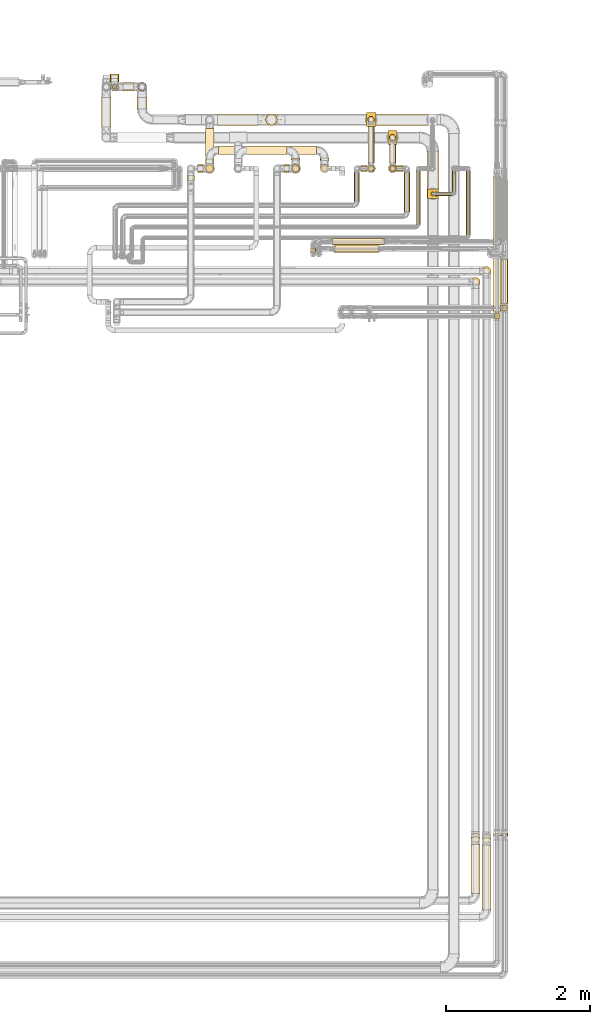
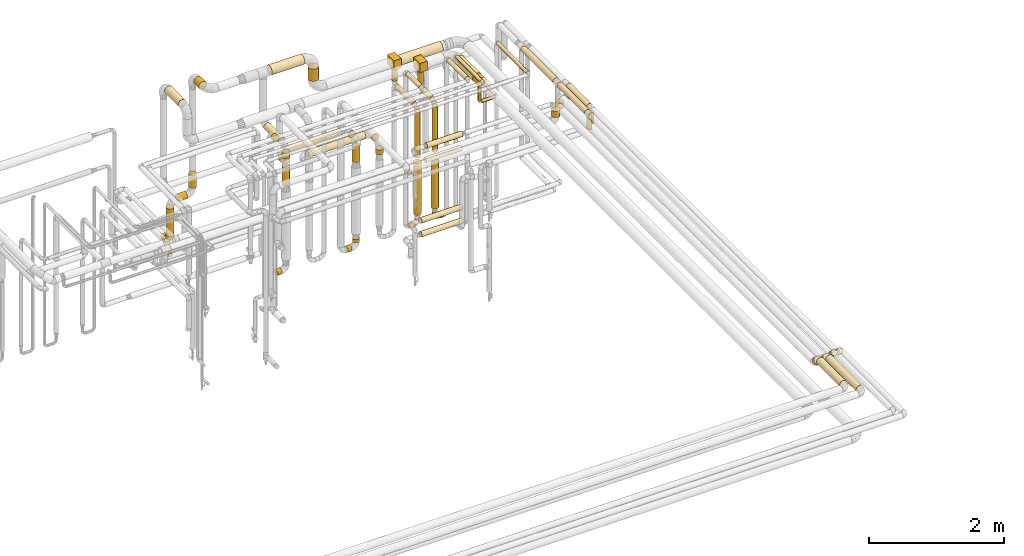
# One storey, part 18 of 827: 66 coverings.
"""IFC2X3 building model written with IfcOpenShell, lengths in millimetres."""

import ifcopenshell
import ifcopenshell.guid

model = None  # the IFC model being written
_history = None  # IfcOwnerHistory: only IFC2X3 demands one
_inside = {}  # id of a spatial element -> (the spatial element, [elements in it])
_under = {}  # id of a project, library or spatial element -> (it, [spatial elements below it])
_declared = {}  # id of a project -> (the project, [libraries it declares])
_typed = {}  # id of a type object -> (the type object, [elements of that type])
_made_of = {}  # id of a material, layer set ... -> (it, [elements and type objects made of it])


def new_model(schema):
    """Start an empty IFC model of exactly this schema.

    Asked for "IFC4X3", IfcOpenShell would pick the latest addendum, in which some entities
    have other attributes; the version numbers below select the first issue.
    IFC2X3 requires an IfcOwnerHistory on every rooted entity: one is made here for all.
    """
    global model, _history
    if schema == "IFC4X3":
        model = ifcopenshell.file(schema_version=(4, 3, 0, 0))
    else:
        model = ifcopenshell.file(schema=schema)
    _inside.clear()
    _under.clear()
    _declared.clear()
    _typed.clear()
    _made_of.clear()
    _history = None
    if model.schema == "IFC2X3":
        org = make("IfcOrganization", Name="unknown")
        user = make(
            "IfcPersonAndOrganization",
            ThePerson=make("IfcPerson", FamilyName="unknown"),
            TheOrganization=org,
        )
        app = make(
            "IfcApplication",
            ApplicationDeveloper=org,
            Version="unknown",
            ApplicationFullName="unknown",
            ApplicationIdentifier="unknown",
        )
        _history = make(
            "IfcOwnerHistory",
            OwningUser=user,
            OwningApplication=app,
            ChangeAction="ADDED",
            CreationDate=0,
        )
    return model


def make(cls, **values):
    """One entity of the class cls with the attributes given. An attribute that is None is left unset."""
    return model.create_entity(
        cls, **{name: value for name, value in values.items() if value is not None}
    )


def entity(cls, *values):
    """Any entity or typed value of the class cls, its attributes in the order of the schema. None: left unset."""
    e = model.create_entity(cls)
    for i, value in enumerate(values):
        if value is not None:
            e[i] = value
    return e


def rooted(cls, **values):
    """An entity with a GlobalId (a new one), such as an element, a storey or a relation."""
    return make(cls, GlobalId=ifcopenshell.guid.new(), OwnerHistory=_history, **values)


def si_unit(unit_type, name, prefix=None):
    """IfcSIUnit, for example si_unit("LENGTHUNIT", "METRE", prefix="MILLI")."""
    return make("IfcSIUnit", UnitType=unit_type, Prefix=prefix, Name=name)


def converted_unit(unit_type, name, factor, base, dimensions=None, offset=None):
    """IfcConversionBasedUnit, such as the inch: factor (a typed value) times the base unit."""
    return make(
        "IfcConversionBasedUnit"
        if offset is None
        else "IfcConversionBasedUnitWithOffset",
        ConversionOffset=offset,
        Dimensions=None
        if dimensions is None
        else entity("IfcDimensionalExponents", *dimensions),
        UnitType=unit_type,
        Name=name,
        ConversionFactor=make(
            "IfcMeasureWithUnit", ValueComponent=factor, UnitComponent=base
        ),
    )


def derived_unit(unit_type, elements):
    """IfcDerivedUnit: a product of units, each with its exponent."""
    return make(
        "IfcDerivedUnit",
        Elements=[
            make("IfcDerivedUnitElement", Unit=unit, Exponent=power)
            for unit, power in elements
        ],
        UnitType=unit_type,
    )


def assignment(units):
    """IfcUnitAssignment: the units of a project."""
    return None if units is None else make("IfcUnitAssignment", Units=units)


def point(xyz):
    """IfcCartesianPoint."""
    return None if xyz is None else make("IfcCartesianPoint", Coordinates=xyz)


def direction(xyz):
    """IfcDirection."""
    return None if xyz is None else make("IfcDirection", DirectionRatios=xyz)


def frame(location, z_axis=None, x_axis=None):
    """IfcAxis2Placement3D, a coordinate frame: its origin and axes. An axis left out is left unset."""
    return make(
        "IfcAxis2Placement3D",
        Location=point(location),
        Axis=direction(z_axis),
        RefDirection=direction(x_axis),
    )


def frame_2d(location, x_axis=None):
    """IfcAxis2Placement2D, a coordinate frame in the plane: its origin and x axis."""
    return make(
        "IfcAxis2Placement2D", Location=point(location), RefDirection=direction(x_axis)
    )


def origin():
    """The frame at (0, 0, 0) with its axes left unset."""
    return frame((0.0, 0.0, 0.0))


def origin_2d_with_axis():
    """The frame at (0, 0) in the plane with the x axis (1, 0) written out."""
    return frame_2d((0.0, 0.0), x_axis=(1.0, 0.0))


def place(relative_to, where):
    """IfcLocalPlacement: puts the frame where relative to a parent placement (None: the world)."""
    return make(
        "IfcLocalPlacement", PlacementRelTo=relative_to, RelativePlacement=where
    )


def context(
    kind, dimensions, precision=None, world=None, true_north=None, identifier=None
):
    """IfcGeometricRepresentationContext, for example the 3D "Model" context."""
    return make(
        "IfcGeometricRepresentationContext",
        ContextIdentifier=identifier,
        ContextType=kind,
        CoordinateSpaceDimension=dimensions,
        Precision=precision,
        WorldCoordinateSystem=world,
        TrueNorth=true_north,
    )


def subcontext(parent, identifier, kind, view, scale=None):
    """IfcGeometricRepresentationSubContext, for example "Body" below "Model"."""
    return make(
        "IfcGeometricRepresentationSubContext",
        ContextIdentifier=identifier,
        ContextType=kind,
        ParentContext=parent,
        TargetScale=scale,
        TargetView=view,
    )


def project(units=None, contexts=None):
    """IfcProject with its units and contexts."""
    return rooted(
        "IfcProject",
        Name="project",
        RepresentationContexts=contexts,
        UnitsInContext=assignment(units),
    )


def spatial(cls, under=None, at=None, **own):
    """A site, building, storey or space (cls), placed at a placement, below another one or the project."""
    s = rooted(cls, ObjectPlacement=at, **own)
    if under is not None:
        _under.setdefault(under.id(), (under, []))[1].append(s)
    return s


def polyline(points):
    """IfcPolyline through the points."""
    return make("IfcPolyline", Points=[point(p) for p in points])


def circle_curve(where, radius):
    """IfcCircle in the frame where."""
    return make("IfcCircle", Position=where, Radius=radius)


def parameter(value):
    """IfcParameterValue: where a trimmed curve begins or ends, as a parameter of its basis curve."""
    return model.create_entity("IfcParameterValue", value)


def trimmed(basis, trim1, trim2, sense, master):
    """IfcTrimmedCurve: the piece of a basis curve between two trims."""
    return make(
        "IfcTrimmedCurve",
        BasisCurve=basis,
        Trim1=trim1,
        Trim2=trim2,
        SenseAgreement=sense,
        MasterRepresentation=master,
    )


def segment(curve, same_sense, transition):
    """IfcCompositeCurveSegment."""
    return make(
        "IfcCompositeCurveSegment",
        Transition=transition,
        SameSense=same_sense,
        ParentCurve=curve,
    )


def composite_curve(segments, self_intersect=None):
    """IfcCompositeCurve: segments joined end to end."""
    return make("IfcCompositeCurve", Segments=segments, SelfIntersect=self_intersect)


def profile(cls, at=None, kind="AREA", **sizes):
    """A parametric profile (cls). Its sizes go by their IFC names, for example OverallWidth=200.0."""
    return make(cls, ProfileType=kind, Position=at, **sizes)


def rectangle(**sizes):
    """IfcRectangleProfileDef."""
    return profile("IfcRectangleProfileDef", **sizes)


def circle(**sizes):
    """IfcCircleProfileDef."""
    return profile("IfcCircleProfileDef", **sizes)


def outline(outer, holes=None, kind="AREA"):
    """IfcArbitraryClosedProfileDef: a profile drawn as a closed curve; with holes, ...WithVoids."""
    if holes is None:
        return make("IfcArbitraryClosedProfileDef", ProfileType=kind, OuterCurve=outer)
    return make(
        "IfcArbitraryProfileDefWithVoids",
        ProfileType=kind,
        OuterCurve=outer,
        InnerCurves=holes,
    )


def extrude(swept, where, along, depth):
    """IfcExtrudedAreaSolid: the profile swept, set in the frame where, extruded along a direction by depth."""
    return make(
        "IfcExtrudedAreaSolid",
        SweptArea=swept,
        Position=where,
        ExtrudedDirection=direction(along),
        Depth=depth,
    )


def shape(context_of_items, identifier, shape_type, items):
    """IfcShapeRepresentation: the items that make up one representation, for example the "Body"."""
    return make(
        "IfcShapeRepresentation",
        ContextOfItems=context_of_items,
        RepresentationIdentifier=identifier,
        RepresentationType=shape_type,
        Items=items,
    )


def made_of(thing, what):
    """Note that an element or type object is made of a material, layer set ...; save() writes the relation."""
    if what is not None:
        _made_of.setdefault(what.id(), (what, []))[1].append(thing)
    return thing


def element(
    cls,
    number,
    at=None,
    inside=None,
    cuts=None,
    type_object=None,
    material=None,
    context=None,
    identifier="Body",
    shape_type=None,
    held_by="IfcProductDefinitionShape",
    body=None,
    shapes=None,
    **own,
):
    """One element of the class cls, such as IfcWall. Its Tag is "e" and its number.

    at: its placement. inside: the storey or other place that contains it. cuts: it is an
    opening in that element (IfcRelVoidsElement). A single representation is given by context,
    identifier, shape_type and body (its items); several are given by shapes. held_by: the class
    of the entity that holds the representations. save() writes the other relations.
    """
    e = rooted(cls, Tag="e%d" % number, ObjectPlacement=at, **own)
    if body is not None:
        shapes = [shape(context, identifier, shape_type, body)]
    if shapes is not None:
        e.Representation = make(held_by, Representations=shapes)
    if inside is not None:
        _inside.setdefault(inside.id(), (inside, []))[1].append(e)
    if cuts is not None:
        rooted(
            "IfcRelVoidsElement", RelatingBuildingElement=cuts, RelatedOpeningElement=e
        )
    if type_object is not None:
        _typed.setdefault(type_object.id(), (type_object, []))[1].append(e)
    return made_of(e, material)


def aggregate(whole, parts):
    """IfcRelAggregates: a whole, such as a stair, and the parts it consists of."""
    return rooted("IfcRelAggregates", RelatingObject=whole, RelatedObjects=parts)


def save(model, path):
    """Write the relations noted so far, then the file.

    IfcRelAggregates (storeys below a building ...), IfcRelContainedInSpatialStructure (elements
    in a storey), IfcRelDefinesByType, IfcRelAssociatesMaterial and IfcRelDeclares: one each for
    every whole, place, type object, material and project.
    """
    for whole, parts in _under.values():
        aggregate(whole, parts)
    for where, things in _inside.values():
        rooted(
            "IfcRelContainedInSpatialStructure",
            RelatedElements=things,
            RelatingStructure=where,
        )
    for kind, things in _typed.values():
        rooted("IfcRelDefinesByType", RelatedObjects=things, RelatingType=kind)
    for what, things in _made_of.values():
        rooted("IfcRelAssociatesMaterial", RelatedObjects=things, RelatingMaterial=what)
    for by, libraries in _declared.values():
        rooted("IfcRelDeclares", RelatingContext=by, RelatedDefinitions=libraries)
    model.write(path)


model = new_model("IFC2X3")

# Units and contexts
model_context = context("Model", 3, precision=0.01, world=origin(), true_north=direction((6.12303176911189e-17, 1.0)))
body_context = subcontext(model_context, "Body", "Model", "MODEL_VIEW")
ifc_project = project(units=[si_unit("LENGTHUNIT", "METRE", prefix="MILLI"), si_unit("AREAUNIT", "SQUARE_METRE"), si_unit("VOLUMEUNIT", "CUBIC_METRE"), converted_unit("PLANEANGLEUNIT", "DEGREE", entity("IfcRatioMeasure", 0.0174532925199433), si_unit("PLANEANGLEUNIT", "RADIAN"), dimensions=[0, 0, 0, 0, 0, 0, 0]), si_unit("MASSUNIT", "GRAM", prefix="KILO"), derived_unit("MASSDENSITYUNIT", [(si_unit("MASSUNIT", "GRAM", prefix="KILO"), 1), (si_unit("LENGTHUNIT", "METRE"), -3)]), derived_unit("MOMENTOFINERTIAUNIT", [(si_unit("LENGTHUNIT", "METRE"), 4)]), si_unit("TIMEUNIT", "SECOND"), si_unit("FREQUENCYUNIT", "HERTZ"), si_unit("THERMODYNAMICTEMPERATUREUNIT", "DEGREE_CELSIUS"), derived_unit("THERMALTRANSMITTANCEUNIT", [(si_unit("MASSUNIT", "GRAM", prefix="KILO"), 1), (si_unit("THERMODYNAMICTEMPERATUREUNIT", "KELVIN"), -1), (si_unit("TIMEUNIT", "SECOND"), -3)]), derived_unit("VOLUMETRICFLOWRATEUNIT", [(si_unit("LENGTHUNIT", "METRE"), 3), (si_unit("TIMEUNIT", "SECOND"), -1)]), derived_unit("MASSFLOWRATEUNIT", [(si_unit("MASSUNIT", "GRAM", prefix="KILO"), 1), (si_unit("TIMEUNIT", "SECOND"), -1)]), derived_unit("ROTATIONALFREQUENCYUNIT", [(si_unit("TIMEUNIT", "SECOND"), -1)]), si_unit("ELECTRICCURRENTUNIT", "AMPERE"), si_unit("ELECTRICVOLTAGEUNIT", "VOLT"), si_unit("POWERUNIT", "WATT"), si_unit("FORCEUNIT", "NEWTON", prefix="KILO"), si_unit("ILLUMINANCEUNIT", "LUX"), si_unit("LUMINOUSFLUXUNIT", "LUMEN"), si_unit("LUMINOUSINTENSITYUNIT", "CANDELA"), derived_unit("USERDEFINED", [(si_unit("MASSUNIT", "GRAM", prefix="KILO"), -1), (si_unit("LENGTHUNIT", "METRE"), -2), (si_unit("TIMEUNIT", "SECOND"), 3), (si_unit("LUMINOUSFLUXUNIT", "LUMEN"), 1)]), derived_unit("LINEARVELOCITYUNIT", [(si_unit("LENGTHUNIT", "METRE"), 1), (si_unit("TIMEUNIT", "SECOND"), -1)]), si_unit("PRESSUREUNIT", "PASCAL"), derived_unit("USERDEFINED", [(si_unit("LENGTHUNIT", "METRE"), -2), (si_unit("MASSUNIT", "GRAM", prefix="KILO"), 1), (si_unit("TIMEUNIT", "SECOND"), -2)]), derived_unit("LINEARFORCEUNIT", [(si_unit("MASSUNIT", "GRAM", prefix="KILO"), 1), (si_unit("LENGTHUNIT", "METRE"), 1), (si_unit("TIMEUNIT", "SECOND"), -2), (si_unit("LENGTHUNIT", "METRE"), -1)]), derived_unit("PLANARFORCEUNIT", [(si_unit("MASSUNIT", "GRAM", prefix="KILO"), 1), (si_unit("LENGTHUNIT", "METRE"), 1), (si_unit("TIMEUNIT", "SECOND"), -2), (si_unit("LENGTHUNIT", "METRE"), -2)])], contexts=[model_context])

# Site, building, storey
site_placement = place(None, origin())
site = spatial("IfcSite", under=ifc_project, at=site_placement, CompositionType="ELEMENT")
building_placement = place(site_placement, origin())
building = spatial("IfcBuilding", under=site, at=building_placement, CompositionType="ELEMENT")
storey_placement = place(building_placement, frame((0.0, 0.0, 28200.0)))
storey = spatial("IfcBuildingStorey", under=building, at=storey_placement, Name="08", CompositionType="ELEMENT", Elevation=28200.0)

# Coverings
covering_1_placement = place(storey_placement, frame((60838.76, 16008.03, 2795.04)))
element("IfcCovering", 1, at=covering_1_placement, inside=storey, Name=":ADSK_", ObjectType=":ADSK_", PredefinedType="INSULATION", context=body_context, shape_type="SweptSolid", body=[
    extrude(circle(Radius=62.75, at=origin_2d_with_axis()), frame((64.35, 64.35, 0.0)), (0.0, 0.0, 1.0), 109.962845985803),
])
covering_2_placement = place(storey_placement, frame((59550.07, 17576.0, 2448.15)))
element("IfcCovering", 2, at=covering_2_placement, inside=storey, Name=":ADSK_", ObjectType=":ADSK_", PredefinedType="INSULATION", context=body_context, shape_type="SweptSolid", body=[
    extrude(circle(Radius=45.0, at=origin_2d_with_axis()), frame((46.6, 0.0, 46.6), z_axis=(0.0, 1.0, 0.0), x_axis=(1.0, 0.0, 0.0)), (0.0, 0.0, 1.0), 278.096097794324),
])
covering_3_placement = place(storey_placement, frame((59550.07, 17453.4, 1602.24)))
element("IfcCovering", 3, at=covering_3_placement, inside=storey, Name=":ADSK_", ObjectType=":ADSK_", PredefinedType="INSULATION", context=body_context, shape_type="SweptSolid", body=[
    extrude(circle(Radius=45.0, at=origin_2d_with_axis()), frame((46.6, 46.6, 0.0), z_axis=(0.0, 0.0, 1.0), x_axis=(0.0, 1.0, 0.0)), (0.0, 0.0, 1.0), 816.499999999996),
])
covering_4_placement = place(storey_placement, frame((60128.55, 17117.79, 2531.09)))
element("IfcCovering", 4, at=covering_4_placement, inside=storey, Name=":ADSK_", ObjectType=":ADSK_", PredefinedType="INSULATION", context=body_context, shape_type="SweptSolid", body=[
    extrude(circle(Radius=28.4, at=origin_2d_with_axis()), frame((30.0, 30.0, 0.0), z_axis=(-1.46203474159763e-05, 0.0, 1.0), x_axis=(0.0, 1.0, 0.0)), (0.0, 0.0, 1.0), 298.905011104185),
])
covering_5_placement = place(storey_placement, frame((60075.45, 17212.79, 2816.87)))
element("IfcCovering", 5, at=covering_5_placement, inside=storey, Name=":ADSK_", ObjectType=":ADSK_", PredefinedType="INSULATION", context=body_context, shape_type="SweptSolid", body=[
    extrude(circle(Radius=81.5, at=origin_2d_with_axis()), frame((83.1, 0.0, 83.1), z_axis=(0.0, 1.0, 0.0), x_axis=(1.0, 0.0, 0.0)), (0.0, 0.0, 1.0), 527.308325226667),
])
covering_6_placement = place(storey_placement, frame((60187.65, 17117.79, 2472.0)))
element("IfcCovering", 6, at=covering_6_placement, inside=storey, Name=":ADSK_", ObjectType=":ADSK_", PredefinedType="INSULATION", context=body_context, shape_type="SweptSolid", body=[
    extrude(circle(Radius=28.4, at=origin_2d_with_axis()), frame((0.0, 30.0, 30.0), z_axis=(1.0, 0.0, 0.0), x_axis=(0.0, 1.0, 0.0)), (0.0, 0.0, 1.0), 237.633062103833),
])
covering_7_placement = place(storey_placement, frame((60424.39, 17176.89, 2472.0)))
element("IfcCovering", 7, at=covering_7_placement, inside=storey, Name=":ADSK_", ObjectType=":ADSK_", PredefinedType="INSULATION", context=body_context, shape_type="SweptSolid", body=[
    extrude(circle(Radius=28.4, at=origin_2d_with_axis()), frame((30.0, 0.0, 30.0), z_axis=(0.0, 1.0, 0.0), x_axis=(-1.0, 0.0, 0.0)), (0.0, 0.0, 1.0), 294.012227432359),
])
covering_8_placement = place(storey_placement, frame((58588.54, 17614.0, 2039.15)))
element("IfcCovering", 8, at=covering_8_placement, inside=storey, Name=":ADSK_", ObjectType=":ADSK_", PredefinedType="INSULATION", context=body_context, shape_type="SweptSolid", body=[
    extrude(circle(Radius=59.25, at=origin_2d_with_axis()), frame((60.85, 0.0, 60.85), z_axis=(0.0, 1.0, 0.0), x_axis=(1.0, 0.0, 0.0)), (0.0, 0.0, 1.0), 27.0961141089868),
])
covering_9_placement = place(storey_placement, frame((58588.54, 17439.15, 1898.17)))
element("IfcCovering", 9, at=covering_9_placement, inside=storey, Name=":ADSK_", ObjectType=":ADSK_", PredefinedType="INSULATION", context=body_context, shape_type="SweptSolid", body=[
    extrude(circle(Radius=59.25, at=origin_2d_with_axis()), frame((60.85, 60.85, 0.0)), (0.0, 0.0, 1.0), 87.8307333425285),
])
covering_10_placement = place(storey_placement, frame((61002.04, 16436.84, 2949.15)))
element("IfcCovering", 10, at=covering_10_placement, inside=storey, Name=":ADSK_", ObjectType=":ADSK_", PredefinedType="INSULATION", context=body_context, shape_type="SweptSolid", body=[
    extrude(circle(Radius=49.0, at=origin_2d_with_axis()), frame((50.6, 0.0, 50.6), z_axis=(0.0, 1.0, 0.0), x_axis=(1.0, 0.0, 0.0)), (0.0, 0.0, 1.0), 958.995662655606),
])
covering_11_placement = place(storey_placement, frame((61002.04, 15501.21, 2949.15)))
element("IfcCovering", 11, at=covering_11_placement, inside=storey, Name=":ADSK_", ObjectType=":ADSK_", PredefinedType="INSULATION", context=body_context, shape_type="SweptSolid", body=[
    extrude(circle(Radius=49.0, at=origin_2d_with_axis()), frame((50.6, 0.0, 50.6), z_axis=(0.0, 1.0, 0.0), x_axis=(-1.0, 0.0, 0.0)), (0.0, 0.0, 1.0), 821.627947057632),
])
covering_12_placement = place(storey_placement, frame((61009.29, 15400.86, 2738.0)))
element("IfcCovering", 12, at=covering_12_placement, inside=storey, Name=":ADSK_", ObjectType=":ADSK_", PredefinedType="INSULATION", context=body_context, shape_type="SweptSolid", body=[
    extrude(circle(Radius=41.75, at=origin_2d_with_axis()), frame((43.35, 43.35, 0.0), z_axis=(0.0, 0.0, 1.0), x_axis=(0.0, -1.0, 0.0)), (0.0, 0.0, 1.0), 204.743188805694),
])
covering_13_placement = place(storey_placement, frame((61102.04, 15617.52, 2949.15)))
element("IfcCovering", 13, at=covering_13_placement, inside=storey, Name=":ADSK_", ObjectType=":ADSK_", PredefinedType="INSULATION", context=body_context, shape_type="SweptSolid", body=[
    extrude(circle(Radius=49.0, at=origin_2d_with_axis()), frame((50.6, 0.0, 50.6), z_axis=(0.0, 1.0, 0.0), x_axis=(-1.0, 0.0, 0.0)), (0.0, 0.0, 1.0), 614.353457594442),
])
covering_14_placement = place(storey_placement, frame((61109.29, 15517.18, 2738.0)))
element("IfcCovering", 14, at=covering_14_placement, inside=storey, Name=":ADSK_", ObjectType=":ADSK_", PredefinedType="INSULATION", context=body_context, shape_type="SweptSolid", body=[
    extrude(circle(Radius=41.75, at=origin_2d_with_axis()), frame((43.35, 43.35, 0.0), z_axis=(0.0, 0.0, 1.0), x_axis=(0.0, -1.0, 0.0)), (0.0, 0.0, 1.0), 204.743188805685),
])
covering_15_placement = place(storey_placement, frame((55540.45, 18080.1, 3429.4)))
element("IfcCovering", 15, at=covering_15_placement, inside=storey, Name=":ADSK_", ObjectType=":ADSK_", PredefinedType="INSULATION", context=body_context, shape_type="SweptSolid", body=[
    extrude(circle(Radius=69.0, at=origin_2d_with_axis()), frame((70.6, 0.0, 70.6), z_axis=(0.0, 1.0, 0.0), x_axis=(-1.0, 0.0, 0.0)), (0.0, 0.0, 1.0), 405.890503073728),
])
covering_16_placement = place(storey_placement, frame((59550.07, 17883.5, 2570.74)))
element("IfcCovering", 16, at=covering_16_placement, inside=storey, Name=":ADSK_", ObjectType=":ADSK_", PredefinedType="INSULATION", context=body_context, shape_type="SweptSolid", body=[
    extrude(circle(Radius=45.0, at=origin_2d_with_axis()), frame((46.6, 46.6, 0.0)), (0.0, 0.0, 1.0), 259.256811194313),
])
covering_17_placement = place(storey_placement, frame((59531.67, 17833.85, 2830.0)))
element("IfcCovering", 17, at=covering_17_placement, inside=storey, Name=":ADSK_", ObjectType=":ADSK_", PredefinedType="INSULATION", context=body_context, shape_type="SweptSolid", body=[
    extrude(rectangle(XDim=129.999999999996, YDim=192.500000000002, at=origin_2d_with_axis()), frame((65.0, 96.25, 0.0), z_axis=(0.0, 0.0, 1.0), x_axis=(-1.0, 0.0, 0.0)), (0.0, 0.0, 1.0), 166.25000000001),
])
covering_18_placement = place(storey_placement, frame((57561.89, 17694.25, 2039.15)))
element("IfcCovering", 18, at=covering_18_placement, inside=storey, Name=":ADSK_", ObjectType=":ADSK_", PredefinedType="INSULATION", context=body_context, shape_type="SweptSolid", body=[
    extrude(circle(Radius=59.25, at=origin_2d_with_axis()), frame((0.0, 60.85, 60.85), z_axis=(1.0, 0.0, 0.0), x_axis=(0.0, 1.0, 0.0)), (0.0, 0.0, 1.0), 973.496500000027),
])
covering_19_placement = place(storey_placement, frame((59757.54, 16894.94, 3159.4)))
element("IfcCovering", 19, at=covering_19_placement, inside=storey, Name=":ADSK_", ObjectType=":ADSK_", PredefinedType="INSULATION", context=body_context, shape_type="SweptSolid", body=[
    extrude(circle(Radius=39.0, at=origin_2d_with_axis()), frame((40.6, 0.0, 40.6), z_axis=(0.0, 1.0, 0.0), x_axis=(1.0, 0.0, 0.0)), (0.0, 0.0, 1.0), 548.064099051886),
])
covering_20_placement = place(storey_placement, frame((59653.67, 17459.4, 359.4)))
element("IfcCovering", 20, at=covering_20_placement, inside=storey, Name=":ADSK_", ObjectType=":ADSK_", PredefinedType="INSULATION", context=body_context, shape_type="SweptSolid", body=[
    extrude(circle(Radius=39.0, at=origin_2d_with_axis()), frame((0.0, 40.6, 40.6), z_axis=(1.0, 0.0, 0.0), x_axis=(0.0, -1.0, 0.0)), (0.0, 0.0, 1.0), 87.4629414974364),
])
covering_21_placement = place(storey_placement, frame((59556.07, 17459.4, 457.0)))
element("IfcCovering", 21, at=covering_21_placement, inside=storey, Name=":ADSK_", ObjectType=":ADSK_", PredefinedType="INSULATION", context=body_context, shape_type="SweptSolid", body=[
    extrude(circle(Radius=39.0, at=origin_2d_with_axis()), frame((40.6, 40.6, 0.0)), (0.0, 0.0, 1.0), 43.0000000000076),
])
covering_22_placement = place(storey_placement, frame((60619.79, 16573.69, 3166.65)))
element("IfcCovering", 22, at=covering_22_placement, inside=storey, Name=":ADSK_", ObjectType=":ADSK_", PredefinedType="INSULATION", context=body_context, shape_type="SweptSolid", body=[
    extrude(circle(Radius=31.75, at=origin_2d_with_axis()), frame((33.35, 0.0, 33.35), z_axis=(0.0, 1.0, 0.0), x_axis=(1.0, 0.0, 0.0)), (0.0, 0.0, 1.0), 888.304686356007),
])
covering_23_placement = place(storey_placement, frame((59535.82, 17439.15, 589.0)))
element("IfcCovering", 23, at=covering_23_placement, inside=storey, Name=":ADSK_", ObjectType=":ADSK_", PredefinedType="INSULATION", context=body_context, shape_type="SweptSolid", body=[
    extrude(circle(Radius=59.25, at=origin_2d_with_axis()), frame((60.85, 60.85, 0.0), z_axis=(0.0, 0.0, 1.0), x_axis=(-1.0, 0.0, 0.0)), (0.0, 0.0, 1.0), 924.243188805704),
])
covering_24_placement = place(storey_placement, frame((58801.1, 16332.09, 2602.25)))
element("IfcCovering", 24, at=covering_24_placement, inside=storey, Name=":ADSK_", ObjectType=":ADSK_", PredefinedType="INSULATION", context=body_context, shape_type="SweptSolid", body=[
    extrude(circle(Radius=46.15, at=origin_2d_with_axis()), frame((0.0, 47.75, 47.75), z_axis=(1.0, 0.0, 0.0), x_axis=(0.0, 1.0, 0.0)), (0.0, 0.0, 1.0), 608.330451835312),
])
covering_25_placement = place(storey_placement, frame((58451.15, 16333.94, 2254.95)))
element("IfcCovering", 25, at=covering_25_placement, inside=storey, Name=":ADSK_", ObjectType=":ADSK_", PredefinedType="INSULATION", context=body_context, shape_type="SweptSolid", body=[
    extrude(circle(Radius=38.45, at=origin_2d_with_axis()), frame((40.05, 0.0, 40.05), z_axis=(0.0, 1.0, 0.0), x_axis=(0.0, 0.0, 1.0)), (0.0, 0.0, 1.0), 49.9999999999995),
])
covering_26_placement = place(storey_placement, frame((58778.82, 16332.09, 2352.25)))
element("IfcCovering", 26, at=covering_26_placement, inside=storey, Name=":ADSK_", ObjectType=":ADSK_", PredefinedType="INSULATION", context=body_context, shape_type="SweptSolid", body=[
    extrude(circle(Radius=46.15, at=origin_2d_with_axis()), frame((0.0, 47.75, 47.75), z_axis=(1.0, 0.0, 0.0), x_axis=(0.0, -1.0, 0.0)), (0.0, 0.0, 1.0), 620.000000000006),
])
covering_27_placement = place(storey_placement, frame((58764.02, 16431.91, 1202.25)))
element("IfcCovering", 27, at=covering_27_placement, inside=storey, Name=":ADSK_", ObjectType=":ADSK_", PredefinedType="INSULATION", context=body_context, shape_type="SweptSolid", body=[
    extrude(circle(Radius=46.15, at=origin_2d_with_axis()), frame((0.0, 47.75, 47.75), z_axis=(1.0, 0.0, 0.0), x_axis=(0.0, 1.0, 0.0)), (0.0, 0.0, 1.0), 698.842962557812),
])
covering_28_placement = place(storey_placement, frame((58764.02, 16431.48, 952.25)))
element("IfcCovering", 28, at=covering_28_placement, inside=storey, Name=":ADSK_", ObjectType=":ADSK_", PredefinedType="INSULATION", context=body_context, shape_type="SweptSolid", body=[
    extrude(circle(Radius=46.15, at=origin_2d_with_axis()), frame((0.0, 47.75, 47.75), z_axis=(1.0, 0.0, 6.7602214637812e-06), x_axis=(0.0, -1.0, 0.0)), (0.0, 0.0, 1.0), 717.619049674226),
])
covering_29_placement = place(storey_placement, frame((61102.04, 8156.92, 2980.19)))
element("IfcCovering", 29, at=covering_29_placement, inside=storey, Name=":ADSK_", ObjectType=":ADSK_", PredefinedType="INSULATION", context=body_context, shape_type="SweptSolid", body=[
    extrude(circle(Radius=49.0, at=origin_2d_with_axis()), frame((50.6, 103.11, 36.24), z_axis=(0.0, -0.707106781186542, 0.707106781186553), x_axis=(1.0, 0.0, 0.0)), (0.0, 0.0, 1.0), 94.5641960007415),
])
covering_30_placement = place(storey_placement, frame((61002.04, 8157.83, 2980.19)))
element("IfcCovering", 30, at=covering_30_placement, inside=storey, Name=":ADSK_", ObjectType=":ADSK_", PredefinedType="INSULATION", context=body_context, shape_type="SweptSolid", body=[
    extrude(circle(Radius=49.0, at=origin_2d_with_axis()), frame((50.6, 103.11, 36.24), z_axis=(0.0, -0.707106781186546, 0.707106781186549), x_axis=(1.0, 0.0, 0.0)), (0.0, 0.0, 1.0), 94.5641960007307),
])
covering_31_placement = place(storey_placement, frame((60838.76, 7175.0, 3035.65)))
element("IfcCovering", 31, at=covering_31_placement, inside=storey, Name=":ADSK_", ObjectType=":ADSK_", PredefinedType="INSULATION", context=body_context, shape_type="SweptSolid", body=[
    extrude(circle(Radius=62.75, at=origin_2d_with_axis()), frame((64.35, 0.0, 64.35), z_axis=(0.0, 1.0, 0.0), x_axis=(-1.0, 0.0, 0.0)), (0.0, 0.0, 1.0), 906.837013694414),
])
covering_32_placement = place(storey_placement, frame((60838.76, 8103.05, 2981.86)))
element("IfcCovering", 32, at=covering_32_placement, inside=storey, Name=":ADSK_", ObjectType=":ADSK_", PredefinedType="INSULATION", context=body_context, shape_type="SweptSolid", body=[
    extrude(circle(Radius=62.75, at=origin_2d_with_axis()), frame((64.35, 90.32, 45.97), z_axis=(0.0, -0.707106781186538, 0.707106781186557), x_axis=(1.0, 0.0, 0.0)), (0.0, 0.0, 1.0), 62.7207793864224),
])
covering_33_placement = place(storey_placement, frame((57827.95, 18097.0, 3090.0)))
element("IfcCovering", 33, at=covering_33_placement, inside=storey, Name=":ADSK_", ObjectType=":ADSK_", PredefinedType="INSULATION", context=body_context, shape_type="SweptSolid", body=[
    extrude(circle(Radius=81.5, at=origin_2d_with_axis()), frame((83.1, 83.1, 0.0), z_axis=(0.0, 0.0, 1.0), x_axis=(-1.0, 0.0, 0.0)), (0.0, 0.0, 1.0), 219.743188805708),
])
covering_34_placement = place(storey_placement, frame((56037.95, 18330.1, 3429.15)))
element("IfcCovering", 34, at=covering_34_placement, inside=storey, Name=":ADSK_", ObjectType=":ADSK_", PredefinedType="INSULATION", context=body_context, shape_type="SweptSolid", body=[
    extrude(circle(Radius=69.0, at=origin_2d_with_axis()), frame((70.6, 0.0, 70.6), z_axis=(0.0, 1.0, 0.0), x_axis=(-1.0, 0.0, 0.0)), (0.0, 0.0, 1.0), 155.890486759072),
])
covering_35_placement = place(storey_placement, frame((55845.5, 18574.89, 1312.79)))
element("IfcCovering", 35, at=covering_35_placement, inside=storey, Name=":ADSK_", ObjectType=":ADSK_", PredefinedType="INSULATION", context=body_context, shape_type="SweptSolid", body=[
    extrude(circle(Radius=59.5, at=origin_2d_with_axis()), frame((0.0, 61.1, 61.1), z_axis=(1.0, 0.0, 0.0), x_axis=(0.0, -1.0, 0.0)), (0.0, 0.0, 1.0), 143.048447506268),
])
covering_36_placement = place(storey_placement, frame((55664.4, 18705.99, 554.4)))
element("IfcCovering", 36, at=covering_36_placement, inside=storey, Name=":ADSK_", ObjectType=":ADSK_", PredefinedType="INSULATION", context=body_context, shape_type="SweptSolid", body=[
    extrude(circle(Radius=59.5, at=origin_2d_with_axis()), frame((61.1, 0.0, 61.1), z_axis=(0.0, 1.0, 0.0), x_axis=(-1.0, 0.0, 0.0)), (0.0, 0.0, 1.0), 49.9999999999995),
])
covering_37_placement = place(storey_placement, frame((55664.4, 18574.89, 695.5)))
element("IfcCovering", 37, at=covering_37_placement, inside=storey, Name=":ADSK_", ObjectType=":ADSK_", PredefinedType="INSULATION", context=body_context, shape_type="SweptSolid", body=[
    extrude(circle(Radius=59.5, at=origin_2d_with_axis()), frame((61.1, 61.1, 0.0), z_axis=(0.0, 0.0, 1.0), x_axis=(0.0, 1.0, 0.0)), (0.0, 0.0, 1.0), 558.388760911339),
])
covering_38_placement = place(storey_placement, frame((57160.07, 18097.0, 3416.65)))
element("IfcCovering", 38, at=covering_38_placement, inside=storey, Name=":ADSK_", ObjectType=":ADSK_", PredefinedType="INSULATION", context=body_context, shape_type="SweptSolid", body=[
    extrude(circle(Radius=81.5, at=origin_2d_with_axis()), frame((0.0, 83.1, 83.1), z_axis=(1.0, 0.0, 0.0), x_axis=(0.0, -1.0, 0.0)), (0.0, 0.0, 1.0), 560.978809127979),
])
covering_39_placement = place(storey_placement, frame((56989.22, 17620.0, 2539.15)))
element("IfcCovering", 39, at=covering_39_placement, inside=storey, Name=":ADSK_", ObjectType=":ADSK_", PredefinedType="INSULATION", context=body_context, shape_type="SweptSolid", body=[
    extrude(circle(Radius=59.25, at=origin_2d_with_axis()), frame((60.85, 0.0, 60.85), z_axis=(0.0, 1.0, 0.0), x_axis=(1.0, 0.0, 0.0)), (0.0, 0.0, 1.0), 440.096114108995),
])
covering_40_placement = place(storey_placement, frame((56989.22, 17439.15, 1892.74)))
element("IfcCovering", 40, at=covering_40_placement, inside=storey, Name=":ADSK_", ObjectType=":ADSK_", PredefinedType="INSULATION", context=body_context, shape_type="SweptSolid", body=[
    extrude(circle(Radius=59.25, at=origin_2d_with_axis()), frame((60.85, 60.85, 0.0), z_axis=(0.0, 0.0, 1.0), x_axis=(0.0, 1.0, 0.0)), (0.0, 0.0, 1.0), 327.256811194285),
])
covering_41_placement = place(storey_placement, frame((56989.22, 17570.0, 2239.15)))
element("IfcCovering", 41, at=covering_41_placement, inside=storey, Name=":ADSK_", ObjectType=":ADSK_", PredefinedType="INSULATION", context=body_context, shape_type="SweptSolid", body=[
    extrude(circle(Radius=59.25, at=origin_2d_with_axis()), frame((60.85, 0.0, 60.85), z_axis=(0.0, 1.0, 0.0), x_axis=(-1.0, 0.0, 0.0)), (0.0, 0.0, 1.0), 65.096114108989),
])
covering_42_placement = place(storey_placement, frame((56989.22, 17439.15, 2380.0)))
element("IfcCovering", 42, at=covering_42_placement, inside=storey, Name=":ADSK_", ObjectType=":ADSK_", PredefinedType="INSULATION", context=body_context, shape_type="SweptSolid", body=[
    extrude(circle(Radius=59.25, at=origin_2d_with_axis()), frame((60.85, 60.85, 0.0), z_axis=(0.0, 0.0, 1.0), x_axis=(0.0, 1.0, 0.0)), (0.0, 0.0, 1.0), 99.7431888057308),
])
covering_43_placement = place(storey_placement, frame((57170.07, 17694.25, 2239.15)))
element("IfcCovering", 43, at=covering_43_placement, inside=storey, Name=":ADSK_", ObjectType=":ADSK_", PredefinedType="INSULATION", context=body_context, shape_type="SweptSolid", body=[
    extrude(circle(Radius=59.25, at=origin_2d_with_axis()), frame((0.0, 60.85, 60.85), z_axis=(1.0, 0.0, 0.0), x_axis=(0.0, 1.0, 0.0)), (0.0, 0.0, 1.0), 957.500000000025),
])
covering_44_placement = place(storey_placement, frame((58186.72, 17620.0, 2239.15)))
element("IfcCovering", 44, at=covering_44_placement, inside=storey, Name=":ADSK_", ObjectType=":ADSK_", PredefinedType="INSULATION", context=body_context, shape_type="SweptSolid", body=[
    extrude(circle(Radius=59.25, at=origin_2d_with_axis()), frame((60.85, 0.0, 60.85), z_axis=(0.0, 1.0, 0.0), x_axis=(1.0, 0.0, 0.0)), (0.0, 0.0, 1.0), 15.0961141089939),
])
covering_45_placement = place(storey_placement, frame((58186.72, 17439.15, 1902.45)))
element("IfcCovering", 45, at=covering_45_placement, inside=storey, Name=":ADSK_", ObjectType=":ADSK_", PredefinedType="INSULATION", context=body_context, shape_type="SweptSolid", body=[
    extrude(circle(Radius=59.25, at=origin_2d_with_axis()), frame((60.85, 60.85, 0.0), z_axis=(0.0, 0.0, 1.0), x_axis=(-1.0, 0.0, 0.0)), (0.0, 0.0, 1.0), 277.547222472813),
])
covering_46_placement = place(storey_placement, frame((59251.3, 18133.5, 2577.24)))
element("IfcCovering", 46, at=covering_46_placement, inside=storey, Name=":ADSK_", ObjectType=":ADSK_", PredefinedType="INSULATION", context=body_context, shape_type="SweptSolid", body=[
    extrude(circle(Radius=45.0, at=origin_2d_with_axis()), frame((46.6, 46.6, 0.0)), (0.0, 0.0, 1.0), 252.756811194297),
])
covering_47_placement = place(storey_placement, frame((59232.89, 18083.85, 2830.0)))
element("IfcCovering", 47, at=covering_47_placement, inside=storey, Name=":ADSK_", ObjectType=":ADSK_", PredefinedType="INSULATION", context=body_context, shape_type="SweptSolid", body=[
    extrude(rectangle(XDim=129.999999999996, YDim=192.500000000002, at=origin_2d_with_axis()), frame((65.0, 96.25, 0.0), z_axis=(0.0, 0.0, 1.0), x_axis=(-1.0, 0.0, 0.0)), (0.0, 0.0, 1.0), 166.25000000001),
])
covering_48_placement = place(storey_placement, frame((59362.89, 18097.0, 2816.9)))
element("IfcCovering", 48, at=covering_48_placement, inside=storey, Name=":ADSK_", ObjectType=":ADSK_", PredefinedType="INSULATION", context=body_context, shape_type="SweptSolid", body=[
    extrude(circle(Radius=81.5, at=origin_2d_with_axis()), frame((0.0, 83.1, 83.1), z_axis=(1.0, 0.0, 0.0), x_axis=(0.0, -1.0, 0.0)), (0.0, 0.0, 1.0), 725.240640582081),
])
covering_49_placement = place(storey_placement, frame((59251.3, 17575.0, 2455.65)))
element("IfcCovering", 49, at=covering_49_placement, inside=storey, Name=":ADSK_", ObjectType=":ADSK_", PredefinedType="INSULATION", context=body_context, shape_type="SweptSolid", body=[
    extrude(circle(Radius=45.0, at=origin_2d_with_axis()), frame((46.6, 0.0, 46.6), z_axis=(0.0, 1.0, 0.0), x_axis=(1.0, 0.0, 0.0)), (0.0, 0.0, 1.0), 530.096114108994),
])
covering_50_placement = place(storey_placement, frame((59251.3, 17453.4, 1602.24)))
element("IfcCovering", 50, at=covering_50_placement, inside=storey, Name=":ADSK_", ObjectType=":ADSK_", PredefinedType="INSULATION", context=body_context, shape_type="SweptSolid", body=[
    extrude(circle(Radius=45.0, at=origin_2d_with_axis()), frame((46.6, 46.6, 0.0), z_axis=(0.0, 0.0, 1.0), x_axis=(0.0, 1.0, 0.0)), (0.0, 0.0, 1.0), 825.000000000016),
])
covering_51_placement = place(storey_placement, frame((59155.13, 17459.4, 359.4)))
element("IfcCovering", 51, at=covering_51_placement, inside=storey, Name=":ADSK_", ObjectType=":ADSK_", PredefinedType="INSULATION", context=body_context, shape_type="SweptSolid", body=[
    extrude(circle(Radius=39.0, at=origin_2d_with_axis()), frame((0.0, 40.6, 40.6), z_axis=(1.0, 0.0, 0.0), x_axis=(0.0, 1.0, 0.0)), (0.0, 0.0, 1.0), 86.0000000000064),
])
covering_52_placement = place(storey_placement, frame((59257.3, 17459.4, 457.0)))
element("IfcCovering", 52, at=covering_52_placement, inside=storey, Name=":ADSK_", ObjectType=":ADSK_", PredefinedType="INSULATION", context=body_context, shape_type="SweptSolid", body=[
    extrude(circle(Radius=39.0, at=origin_2d_with_axis()), frame((40.6, 40.6, 0.0)), (0.0, 0.0, 1.0), 33.0000000000055),
])
covering_53_placement = place(storey_placement, frame((58082.89, 17445.65, 295.65)))
element("IfcCovering", 53, at=covering_53_placement, inside=storey, Name=":ADSK_", ObjectType=":ADSK_", PredefinedType="INSULATION", context=body_context, shape_type="SweptSolid", body=[
    extrude(circle(Radius=52.75, at=origin_2d_with_axis()), frame((0.0, 54.35, 54.35), z_axis=(1.0, 0.0, 0.0), x_axis=(0.0, 1.0, 0.0)), (0.0, 0.0, 1.0), 69.6845769329227),
])
covering_54_placement = place(storey_placement, frame((58193.22, 17445.65, 445.0)))
element("IfcCovering", 54, at=covering_54_placement, inside=storey, Name=":ADSK_", ObjectType=":ADSK_", PredefinedType="INSULATION", context=body_context, shape_type="SweptSolid", body=[
    extrude(circle(Radius=52.75, at=origin_2d_with_axis()), frame((54.35, 54.35, 0.0)), (0.0, 0.0, 1.0), 55.0000000000005),
])
covering_55_placement = place(storey_placement, frame((56882.39, 17445.65, 298.15)))
element("IfcCovering", 55, at=covering_55_placement, inside=storey, Name=":ADSK_", ObjectType=":ADSK_", PredefinedType="INSULATION", context=body_context, shape_type="SweptSolid", body=[
    extrude(circle(Radius=52.75, at=origin_2d_with_axis()), frame((0.0, 54.35, 54.35), z_axis=(1.0, 0.0, 0.0), x_axis=(0.0, 1.0, 0.0)), (0.0, 0.0, 1.0), 72.6845769329567),
])
covering_56_placement = place(storey_placement, frame((59919.79, 16723.69, 3166.65)))
element("IfcCovering", 56, at=covering_56_placement, inside=storey, Name=":ADSK_", ObjectType=":ADSK_", PredefinedType="INSULATION", context=body_context, shape_type="SweptSolid", body=[
    extrude(circle(Radius=31.75, at=origin_2d_with_axis()), frame((33.35, 0.0, 33.35), z_axis=(0.0, 1.0, 0.0), x_axis=(1.0, 0.0, 0.0)), (0.0, 0.0, 1.0), 738.30468635603),
])
covering_57_placement = place(storey_placement, frame((59057.54, 17042.69, 3159.4)))
element("IfcCovering", 57, at=covering_57_placement, inside=storey, Name=":ADSK_", ObjectType=":ADSK_", PredefinedType="INSULATION", context=body_context, shape_type="SweptSolid", body=[
    extrude(circle(Radius=39.0, at=origin_2d_with_axis()), frame((40.6, 0.0, 40.6), z_axis=(0.0, 1.0, 0.0), x_axis=(1.0, 0.0, 0.0)), (0.0, 0.0, 1.0), 400.304686356029),
])
covering_58_placement = place(storey_placement, frame((56047.45, 18574.89, 1493.89)))
element("IfcCovering", 58, at=covering_58_placement, inside=storey, Name=":ADSK_", ObjectType=":ADSK_", PredefinedType="INSULATION", context=body_context, shape_type="SweptSolid", body=[
    extrude(circle(Radius=59.5, at=origin_2d_with_axis()), frame((61.1, 61.1, 0.0), z_axis=(0.0, 0.0, 1.0), x_axis=(-1.0, 0.0, 0.0)), (0.0, 0.0, 1.0), 231.111239088707),
])
covering_59_placement = place(storey_placement, frame((55691.4, 18601.89, 369.5)))
element("IfcCovering", 59, at=covering_59_placement, inside=storey, Name=":ADSK_", ObjectType=":ADSK_", PredefinedType="INSULATION", context=body_context, shape_type="SweptSolid", body=[
    extrude(circle(Radius=32.5, at=origin_2d_with_axis()), frame((34.1, 34.1, 0.0), z_axis=(0.0, 0.0, 1.0), x_axis=(0.0, 1.0, 0.0)), (0.0, 0.0, 1.0), 61.0000000000035),
])
covering_60_placement = place(storey_placement, frame((55664.4, 18755.99, 554.4)))
element("IfcCovering", 60, at=covering_60_placement, inside=storey, Name=":ADSK_", ObjectType=":ADSK_", PredefinedType="INSULATION", context=body_context, shape_type="SweptSolid", body=[
    extrude(circle(Radius=59.5, at=origin_2d_with_axis()), frame((61.1, 0.0, 61.1), z_axis=(0.0, 1.0, 0.0), x_axis=(-1.0, 0.0, 0.0)), (0.0, 0.0, 1.0), 59.9999999999994),
])
covering_61_placement = place(storey_placement, frame((59237.05, 17439.15, 579.0)))
element("IfcCovering", 61, at=covering_61_placement, inside=storey, Name=":ADSK_", ObjectType=":ADSK_", PredefinedType="INSULATION", context=body_context, shape_type="SweptSolid", body=[
    extrude(circle(Radius=59.25, at=origin_2d_with_axis()), frame((60.85, 60.85, 0.0), z_axis=(0.0, 0.0, 1.0), x_axis=(-1.0, 0.0, 0.0)), (0.0, 0.0, 1.0), 934.243188805697),
])
covering_62_placement = place(storey_placement, frame((60688.76, 15858.03, 2795.0)))
element("IfcCovering", 62, at=covering_62_placement, inside=storey, Name=":ADSK_", ObjectType=":ADSK_", PredefinedType="INSULATION", context=body_context, shape_type="SweptSolid", body=[
    extrude(circle(Radius=62.75, at=origin_2d_with_axis()), frame((64.35, 64.35, 0.0), z_axis=(0.0, 0.0, 1.0), x_axis=(0.0, -1.0, 0.0)), (0.0, 0.0, 1.0), 110.000000000049),
])
covering_63_placement = place(storey_placement, frame((60688.76, 7405.0, 3035.65)))
element("IfcCovering", 63, at=covering_63_placement, inside=storey, Name=":ADSK_", ObjectType=":ADSK_", PredefinedType="INSULATION", context=body_context, shape_type="SweptSolid", body=[
    extrude(circle(Radius=62.75, at=origin_2d_with_axis()), frame((64.35, 0.0, 64.35), z_axis=(0.0, 1.0, 0.0), x_axis=(-1.0, 0.0, 0.0)), (0.0, 0.0, 1.0), 685.663833694496),
])
covering_64_placement = place(storey_placement, frame((60688.76, 8111.87, 2981.86)))
element("IfcCovering", 64, at=covering_64_placement, inside=storey, Name=":ADSK_", ObjectType=":ADSK_", PredefinedType="INSULATION", context=body_context, shape_type="SweptSolid", body=[
    extrude(circle(Radius=62.75, at=origin_2d_with_axis()), frame((64.35, 90.32, 45.97), z_axis=(0.0, -0.707106781186546, 0.707106781186549), x_axis=(1.0, 0.0, 0.0)), (0.0, 0.0, 1.0), 62.7207793864289),
])
covering_65_placement = place(storey_placement, frame((56733.04, 17335.0, 2845.65)))
element("IfcCovering", 65, at=covering_65_placement, inside=storey, Name=":ADSK_", ObjectType=":ADSK_", PredefinedType="INSULATION", context=body_context, shape_type="SweptSolid", body=[
    extrude(circle(Radius=52.75, at=origin_2d_with_axis()), frame((54.35, 0.0, 54.35), z_axis=(0.0, 1.0, 0.0), x_axis=(-1.0, 0.0, 0.0)), (0.0, 0.0, 1.0), 70.0000000000187),
])
covering_66_placement = place(storey_placement, frame((60076.95, 17082.79, 2828.4)))
element("IfcCovering", 66, at=covering_66_placement, inside=storey, Name=":ADSK_", ObjectType=":ADSK_", PredefinedType="INSULATION", context=body_context, shape_type="SweptSolid", body=[
    extrude(outline(composite_curve([segment(trimmed(circle_curve(frame_2d((12.0, 0.0), x_axis=(1.0, 0.0)), 80.0), [parameter(0.0)], [parameter(90.0)], True, "PARAMETER"), True, "CONTINUOUS"), segment(trimmed(circle_curve(frame_2d((12.0, 0.0), x_axis=(1.0, 0.0)), 80.0), [parameter(90.0)], [parameter(151.044975628142)], True, "PARAMETER"), True, "CONTINUOUS"), segment(polyline([(-58.0, 38.73), (-58.0, -38.73)]), True, "CONTINUOUS"), segment(trimmed(circle_curve(frame_2d((12.0, 0.0), x_axis=(1.0, 0.0)), 80.0), [parameter(208.955024371858)], [parameter(270.0)], True, "PARAMETER"), True, "CONTINUOUS"), segment(trimmed(circle_curve(frame_2d((12.0, 0.0), x_axis=(1.0, 0.0)), 80.0), [parameter(270.0)], [parameter(0.0)], True, "PARAMETER"), True, "CONTINUOUS")], self_intersect=False)), frame((81.6, 0.0, 59.6), z_axis=(0.0, 1.0, 0.0), x_axis=(0.0, 0.0, 1.0)), (0.0, 0.0, 1.0), 129.999999999996),
])

save(model, "model.ifc")
